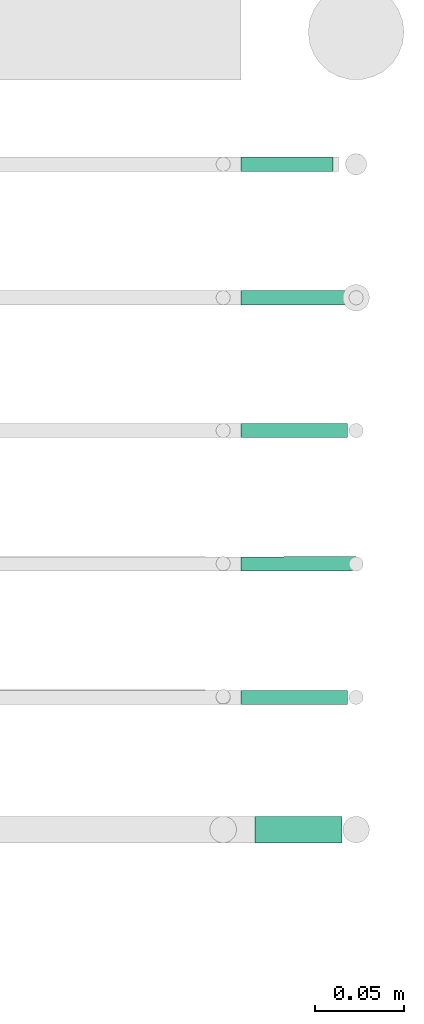
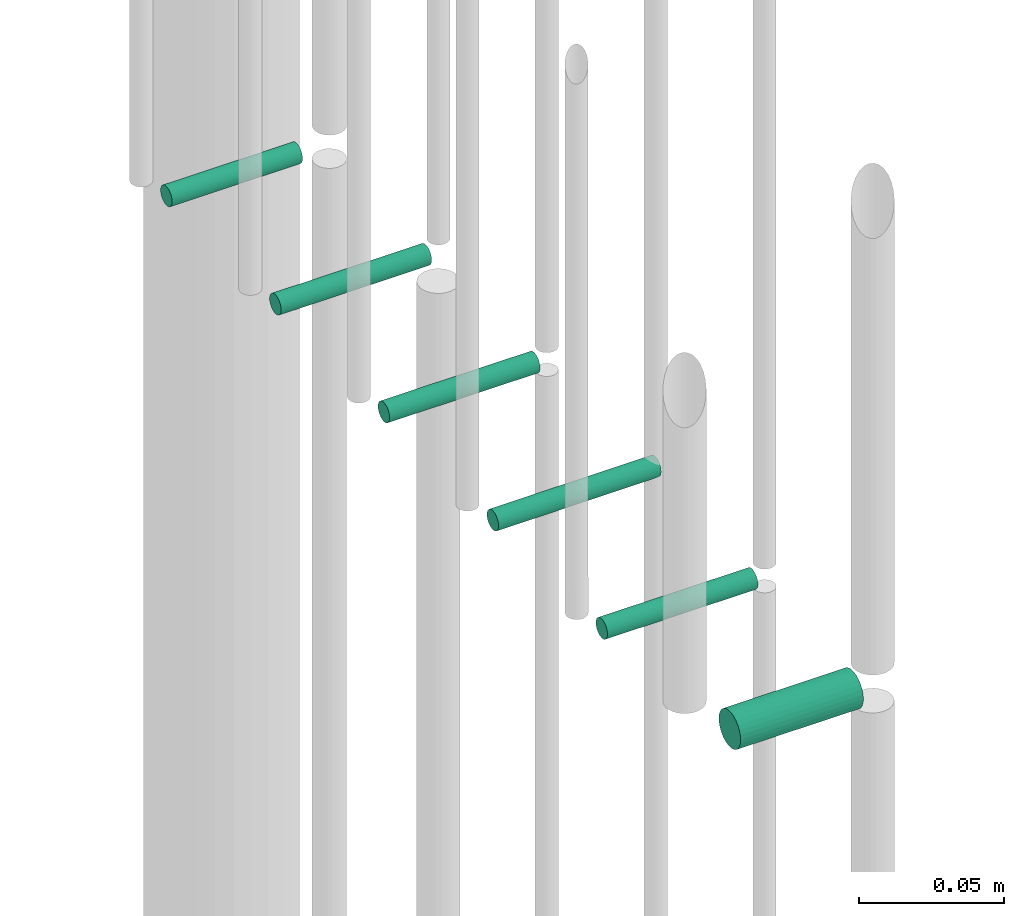
# One storey, part 84 of 89: 6 flow segments.
"""IFC2X3 building model written with IfcOpenShell, lengths in millimetres."""

from ifc_helpers import new_model, entity, si_unit, converted_unit, derived_unit, direction, frame, origin, origin_2d_with_axis, place, context, subcontext, project, spatial, circle, extrude, type_object, element, save


model = new_model("IFC2X3")

# Units and contexts
model_context = context("Model", 3, precision=0.01, world=origin(), true_north=direction((6.12303176911189e-17, 1.0)))
body_context = subcontext(model_context, "Body", "Model", "MODEL_VIEW")
ifc_project = project(units=[si_unit("LENGTHUNIT", "METRE", prefix="MILLI"), si_unit("AREAUNIT", "SQUARE_METRE"), si_unit("VOLUMEUNIT", "CUBIC_METRE"), converted_unit("PLANEANGLEUNIT", "DEGREE", entity("IfcRatioMeasure", 0.0174532925199433), si_unit("PLANEANGLEUNIT", "RADIAN"), dimensions=[0, 0, 0, 0, 0, 0, 0]), si_unit("MASSUNIT", "GRAM", prefix="KILO"), derived_unit("MASSDENSITYUNIT", [(si_unit("MASSUNIT", "GRAM", prefix="KILO"), 1), (si_unit("LENGTHUNIT", "METRE"), -3)]), derived_unit("MOMENTOFINERTIAUNIT", [(si_unit("LENGTHUNIT", "METRE"), 4)]), si_unit("TIMEUNIT", "SECOND"), si_unit("FREQUENCYUNIT", "HERTZ"), si_unit("THERMODYNAMICTEMPERATUREUNIT", "DEGREE_CELSIUS"), derived_unit("THERMALTRANSMITTANCEUNIT", [(si_unit("MASSUNIT", "GRAM", prefix="KILO"), 1), (si_unit("THERMODYNAMICTEMPERATUREUNIT", "KELVIN"), -1), (si_unit("TIMEUNIT", "SECOND"), -3)]), derived_unit("VOLUMETRICFLOWRATEUNIT", [(si_unit("LENGTHUNIT", "METRE"), 3), (si_unit("TIMEUNIT", "SECOND"), -1)]), derived_unit("MASSFLOWRATEUNIT", [(si_unit("MASSUNIT", "GRAM", prefix="KILO"), 1), (si_unit("TIMEUNIT", "SECOND"), -1)]), derived_unit("ROTATIONALFREQUENCYUNIT", [(si_unit("TIMEUNIT", "SECOND"), -1)]), si_unit("ELECTRICCURRENTUNIT", "AMPERE"), si_unit("ELECTRICVOLTAGEUNIT", "VOLT"), si_unit("POWERUNIT", "WATT"), si_unit("FORCEUNIT", "NEWTON", prefix="KILO"), si_unit("ILLUMINANCEUNIT", "LUX"), si_unit("LUMINOUSFLUXUNIT", "LUMEN"), si_unit("LUMINOUSINTENSITYUNIT", "CANDELA"), derived_unit("USERDEFINED", [(si_unit("MASSUNIT", "GRAM", prefix="KILO"), -1), (si_unit("LENGTHUNIT", "METRE"), -2), (si_unit("TIMEUNIT", "SECOND"), 3), (si_unit("LUMINOUSFLUXUNIT", "LUMEN"), 1)]), derived_unit("LINEARVELOCITYUNIT", [(si_unit("LENGTHUNIT", "METRE"), 1), (si_unit("TIMEUNIT", "SECOND"), -1)]), si_unit("PRESSUREUNIT", "PASCAL"), derived_unit("USERDEFINED", [(si_unit("LENGTHUNIT", "METRE"), -2), (si_unit("MASSUNIT", "GRAM", prefix="KILO"), 1), (si_unit("TIMEUNIT", "SECOND"), -2)]), derived_unit("LINEARFORCEUNIT", [(si_unit("MASSUNIT", "GRAM", prefix="KILO"), 1), (si_unit("LENGTHUNIT", "METRE"), 1), (si_unit("TIMEUNIT", "SECOND"), -2), (si_unit("LENGTHUNIT", "METRE"), -1)]), derived_unit("PLANARFORCEUNIT", [(si_unit("MASSUNIT", "GRAM", prefix="KILO"), 1), (si_unit("LENGTHUNIT", "METRE"), 1), (si_unit("TIMEUNIT", "SECOND"), -2), (si_unit("LENGTHUNIT", "METRE"), -2)])], contexts=[model_context])

# Site, building, storey
site_placement = place(None, frame((0.0, -0.00077364408347762, 0.0)))
site = spatial("IfcSite", under=ifc_project, at=site_placement, CompositionType="ELEMENT")
building_placement = place(site_placement, origin())
building = spatial("IfcBuilding", under=site, at=building_placement, CompositionType="ELEMENT")
storey_placement = place(building_placement, frame((0.0, 0.0, 24000.0)))
storey = spatial("IfcBuildingStorey", under=building, at=storey_placement, CompositionType="ELEMENT", Elevation=24000.0)

# Flow segments
pipe_segment_type = type_object("IfcPipeSegmentType", PredefinedType="NOTDEFINED")
flow_segment_1_placement = place(storey_placement, frame((73241.6975079725, 10729.5810040732, 1969.40472778549)))
element("IfcFlowSegment", 1, at=flow_segment_1_placement, inside=storey, type_object=pipe_segment_type, context=body_context, shape_type="SweptSolid", body=[
    extrude(circle(Radius=4.0, at=origin_2d_with_axis()), frame((2.49703962253989e-05, 5.59559685095547, 5.59527223591499), z_axis=(1.0, -6.24259842783148e-06, 0.0), x_axis=(-6.24259842783148e-06, -1.0, 0.0)), (0.0, 0.0, 1.0), 52.0000000315469),
])
flow_segment_2_placement = place(storey_placement, frame((73241.6975329085, 10654.2784588154, 1969.40472973662)))
element("IfcFlowSegment", 2, at=flow_segment_2_placement, inside=storey, type_object=pipe_segment_type, context=body_context, shape_type="SweptSolid", body=[
    extrude(circle(Radius=4.0, at=origin_2d_with_axis()), frame((0.0, 5.59527223591499, 5.59527223591499), z_axis=(1.0, 0.0, 0.0), x_axis=(0.0, 1.0, 0.0)), (0.0, 0.0, 1.0), 60.0000000361628),
])
flow_segment_3_placement = place(storey_placement, frame((73241.6975329446, 10579.3450681644, 1969.40472776494)))
element("IfcFlowSegment", 3, at=flow_segment_3_placement, inside=storey, type_object=pipe_segment_type, context=body_context, shape_type="SweptSolid", body=[
    extrude(circle(Radius=4.0, at=origin_2d_with_axis()), frame((0.0, 5.59527223591499, 5.59527223591499), z_axis=(1.0, 0.0, 0.0), x_axis=(0.0, -1.0, 0.0)), (0.0, 0.0, 1.0), 60.0000000000037),
])
flow_segment_4_placement = place(storey_placement, frame((73241.6867850984, 10504.1011222997, 1969.40472776408)))
element("IfcFlowSegment", 4, at=flow_segment_4_placement, inside=storey, type_object=pipe_segment_type, context=body_context, shape_type="SweptSolid", body=[
    extrude(circle(Radius=4.0, at=origin_2d_with_axis()), frame((0.010747846237723, 5.59525779636261, 5.59527223591499), z_axis=(0.999996390112271, 0.00268696156048646, 0.0), x_axis=(0.00268696156048646, -0.999996390112271, 0.0)), (0.0, 0.0, 1.0), 65.0002346460469),
])
flow_segment_5_placement = place(storey_placement, frame((73241.6975329446, 10428.8573992404, 1969.40472766809)))
element("IfcFlowSegment", 5, at=flow_segment_5_placement, inside=storey, type_object=pipe_segment_type, context=body_context, shape_type="SweptSolid", body=[
    extrude(circle(Radius=4.0, at=origin_2d_with_axis()), frame((0.0, 5.59527223592582, 5.59527223591499), z_axis=(1.0, 0.0, 0.0), x_axis=(0.0, -1.0, 0.0)), (0.0, 0.0, 1.0), 60.0000000000037),
])
flow_segment_6_placement = place(storey_placement, frame((73249.6975329446, 10350.7754696782, 1965.90472776408)))
element("IfcFlowSegment", 6, at=flow_segment_6_placement, inside=storey, type_object=pipe_segment_type, context=body_context, shape_type="SweptSolid", body=[
    extrude(circle(Radius=7.5, at=origin_2d_with_axis()), frame((0.0, 9.09527223591853, 9.09527223591419), z_axis=(1.0, 0.0, 0.0), x_axis=(0.0, -1.0, 0.0)), (0.0, 0.0, 1.0), 49.0000000000062),
])

save(model, "model.ifc")
